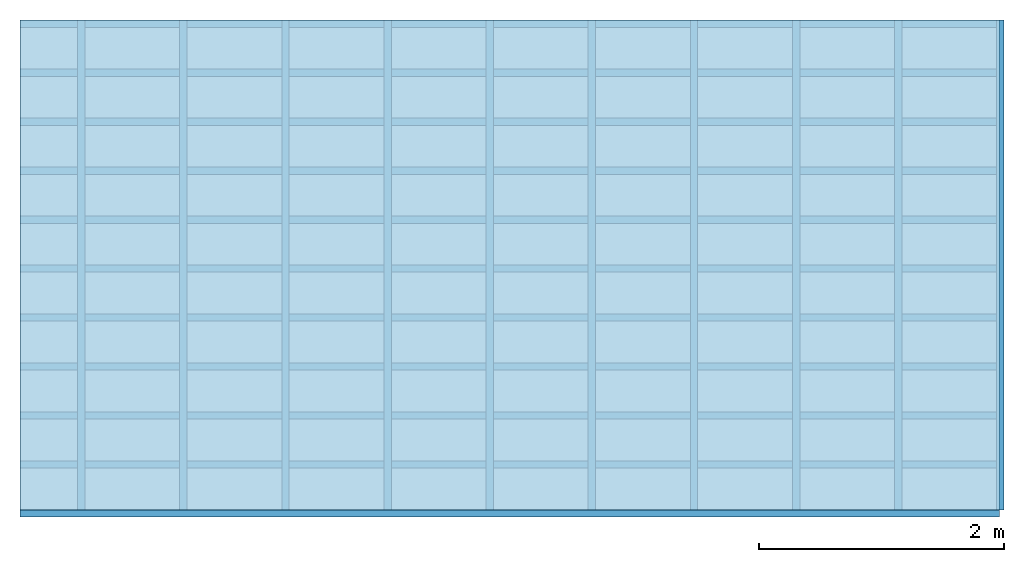
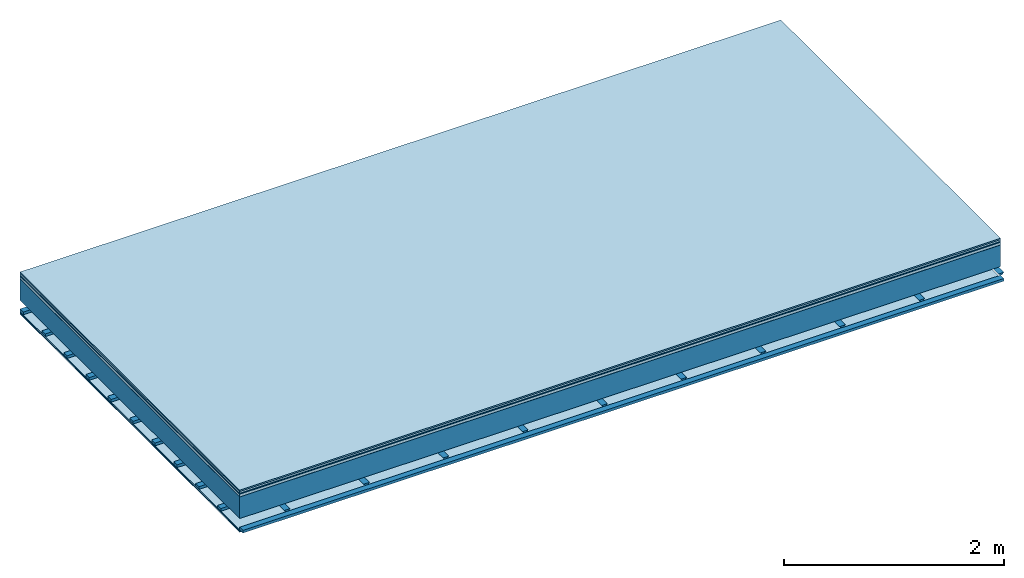
# One storey: 8 plates, 3 members, 1 element without a shape of its own.
"""IFC4 building model written with IfcOpenShell, lengths in metres."""

from ifc_helpers import new_model, si_unit, derived_unit, direction, frame, frame_2d, origin, origin_with_axes, place, context, project, spatial, polyline, rectangle, outline, extrude, material, layer, layer_set, type_object, element, aggregate, save


model = new_model("IFC4")

# Units and contexts
plan_context = context("Plan", 3, precision=1e-05, world=origin(), true_north=direction((0.0, 1.0)))
model_context = context("Model", 3, precision=1e-05, world=origin(), true_north=direction((0.0, 1.0)))
ifc_project = project(units=[si_unit("LENGTHUNIT", "METRE"), derived_unit("SOUNDPRESSUREUNIT", [(si_unit("PRESSUREUNIT", "PASCAL", prefix="MICRO"), 0)]), si_unit("ENERGYUNIT", "JOULE", prefix="MEGA"), si_unit("MASSUNIT", "GRAM", prefix="KILO"), derived_unit("THERMALTRANSMITTANCEUNIT", [(si_unit("POWERUNIT", "WATT"), 1), (si_unit("AREAUNIT", "SQUARE_METRE"), -1), (si_unit("THERMODYNAMICTEMPERATUREUNIT", "KELVIN"), -1)]), derived_unit("AREADENSITYUNIT", [(si_unit("MASSUNIT", "GRAM", prefix="KILO"), 1), (si_unit("AREAUNIT", "SQUARE_METRE"), -1)]), derived_unit("USERDEFINED", [(si_unit("ENERGYUNIT", "JOULE", prefix="MEGA"), 1), (si_unit("AREAUNIT", "SQUARE_METRE"), -1)])], contexts=[plan_context, model_context])

# Site, building, storey
site = spatial("IfcSite", under=ifc_project)
building_placement = place(None, origin())
building = spatial("IfcBuilding", under=site, at=building_placement)
storey_placement = place(building_placement, origin())
storey = spatial("IfcBuildingStorey", under=building, at=storey_placement)

# Slab, members, plates
ifc_material_1 = material(Category="11.013")
ifc_layer_1 = layer(ifc_material_1, 0.015, Name="Flooring")
ifc_material_2 = material(Category="03.007")
ifc_layer_2 = layer(ifc_material_2, 0.02, Name="On-material")
ifc_material_3 = material(Name="Wood fiber generic product", Category="10.009")
ifc_layer_3 = layer(ifc_material_3, 0.01, Name="Impact sound insulation")
ifc_material_4 = material(Name="with broken")
ifc_layer_4 = layer(ifc_material_4, 0.03, Name="on Supporting structure")
ifc_material_5 = material(Name="protection", Category="09.007")
ifc_layer_5 = layer(ifc_material_5, 0.0005, Name="Sub-floor")
ifc_material_6 = material(Name="no composite action")
ifc_layer_6 = layer(ifc_material_6, 0.0, Name="Bond")
ifc_layer_7 = layer(None, 0.24, Name="Supporting structure")
ifc_layer_8 = layer(ifc_material_6, 0.0, Name="Bond")
ifc_layer_9 = layer(None, 0.095, Name="Coupling")
ifc_layer_10 = layer(None, 0.03, Name="Battens / profiles")
ifc_material_7 = material(Name="Plasterboard type A", Category="03.008")
ifc_layer_11 = layer(ifc_material_7, 0.0125, Name="Ceiling covering 1st layer")
ifc_layer_12 = layer(ifc_material_7, 0.0125, Name="Ceiling covering layer 2")
ifc_material_8 = material(Category="04.001")
ifc_layer_13 = layer(ifc_material_8, 0.003, Name="Surface / treatment")
ifc_layer_set = layer_set([ifc_layer_1, ifc_layer_2, ifc_layer_3, ifc_layer_4, ifc_layer_5, ifc_layer_6, ifc_layer_7, ifc_layer_8, ifc_layer_9, ifc_layer_10, ifc_layer_11, ifc_layer_12, ifc_layer_13])
slab_type = type_object("IfcSlabType", Name="A2120", PredefinedType="NOTDEFINED", material=ifc_layer_set)
slab_placement = place(None, frame((0.0, 0.0, 0.0), z_axis=(0.0, 0.0, -1.0), x_axis=(1.0, 0.0, 0.0)))
slab = element("IfcSlab", 1, at=slab_placement, inside=storey, type_object=slab_type, material=ifc_layer_set, Name="Slab #1")
ifc_material_9 = material(Name="Solid timber panel")
member_1_placement = place(slab_placement, origin())
member_1 = element("IfcMember", 2, at=member_1_placement, material=ifc_material_9, Name="Supporting structure", context=plan_context, shape_type="SweptSolid", body=[
    extrude(rectangle(XDim=1.0, YDim=0.24, at=frame_2d((0.5, 0.12), x_axis=(1.0, 0.0))), frame((0.0, 4.0, 0.0755), z_axis=(0.0, -1.0, 0.0), x_axis=(1.0, 0.0, 0.0)), (0.0, 0.0, 1.0), 4.0),
    extrude(rectangle(XDim=1.0, YDim=0.24, at=frame_2d((0.5, 0.12), x_axis=(1.0, 0.0))), frame((1.0, 4.0, 0.0755), z_axis=(0.0, -1.0, 0.0), x_axis=(1.0, 0.0, 0.0)), (0.0, 0.0, 1.0), 4.0),
    extrude(rectangle(XDim=1.0, YDim=0.24, at=frame_2d((0.5, 0.12), x_axis=(1.0, 0.0))), frame((2.0, 4.0, 0.0755), z_axis=(0.0, -1.0, 0.0), x_axis=(1.0, 0.0, 0.0)), (0.0, 0.0, 1.0), 4.0),
    extrude(rectangle(XDim=1.0, YDim=0.24, at=frame_2d((0.5, 0.12), x_axis=(1.0, 0.0))), frame((3.0, 4.0, 0.0755), z_axis=(0.0, -1.0, 0.0), x_axis=(1.0, 0.0, 0.0)), (0.0, 0.0, 1.0), 4.0),
    extrude(rectangle(XDim=1.0, YDim=0.24, at=frame_2d((0.5, 0.12), x_axis=(1.0, 0.0))), frame((4.0, 4.0, 0.0755), z_axis=(0.0, -1.0, 0.0), x_axis=(1.0, 0.0, 0.0)), (0.0, 0.0, 1.0), 4.0),
    extrude(rectangle(XDim=1.0, YDim=0.24, at=frame_2d((0.5, 0.12), x_axis=(1.0, 0.0))), frame((5.0, 4.0, 0.0755), z_axis=(0.0, -1.0, 0.0), x_axis=(1.0, 0.0, 0.0)), (0.0, 0.0, 1.0), 4.0),
    extrude(rectangle(XDim=1.0, YDim=0.24, at=frame_2d((0.5, 0.12), x_axis=(1.0, 0.0))), frame((6.0, 4.0, 0.0755), z_axis=(0.0, -1.0, 0.0), x_axis=(1.0, 0.0, 0.0)), (0.0, 0.0, 1.0), 4.0),
    extrude(rectangle(XDim=1.0, YDim=0.24, at=frame_2d((0.5, 0.12), x_axis=(1.0, 0.0))), frame((7.0, 4.0, 0.0755), z_axis=(0.0, -1.0, 0.0), x_axis=(1.0, 0.0, 0.0)), (0.0, 0.0, 1.0), 4.0),
])
ifc_material_10 = material()
member_2_placement = place(slab_placement, origin())
member_2 = element("IfcMember", 3, at=member_2_placement, material=ifc_material_10, Name="Coupling", context=plan_context, shape_type="SweptSolid", body=[
    extrude(outline(polyline([(0.0, 0.0), (0.06, 0.0), (0.04, 0.02), (0.02, 0.02), (0.0, 0.0)])), frame((0.47, 4.0, 0.3905), z_axis=(0.0, -1.0, 0.0), x_axis=(1.0, 0.0, 0.0)), (0.0, 0.0, 1.0), 4.0),
    extrude(outline(polyline([(0.0, 0.0), (0.06, 0.0), (0.04, 0.02), (0.02, 0.02), (0.0, 0.0)])), frame((1.304, 4.0, 0.3905), z_axis=(0.0, -1.0, 0.0), x_axis=(1.0, 0.0, 0.0)), (0.0, 0.0, 1.0), 4.0),
    extrude(outline(polyline([(0.0, 0.0), (0.06, 0.0), (0.04, 0.02), (0.02, 0.02), (0.0, 0.0)])), frame((2.138, 4.0, 0.3905), z_axis=(0.0, -1.0, 0.0), x_axis=(1.0, 0.0, 0.0)), (0.0, 0.0, 1.0), 4.0),
    extrude(outline(polyline([(0.0, 0.0), (0.06, 0.0), (0.04, 0.02), (0.02, 0.02), (0.0, 0.0)])), frame((2.972, 4.0, 0.3905), z_axis=(0.0, -1.0, 0.0), x_axis=(1.0, 0.0, 0.0)), (0.0, 0.0, 1.0), 4.0),
    extrude(outline(polyline([(0.0, 0.0), (0.06, 0.0), (0.04, 0.02), (0.02, 0.02), (0.0, 0.0)])), frame((3.806, 4.0, 0.3905), z_axis=(0.0, -1.0, 0.0), x_axis=(1.0, 0.0, 0.0)), (0.0, 0.0, 1.0), 4.0),
    extrude(outline(polyline([(0.0, 0.0), (0.06, 0.0), (0.04, 0.02), (0.02, 0.02), (0.0, 0.0)])), frame((4.64, 4.0, 0.3905), z_axis=(0.0, -1.0, 0.0), x_axis=(1.0, 0.0, 0.0)), (0.0, 0.0, 1.0), 4.0),
    extrude(outline(polyline([(0.0, 0.0), (0.06, 0.0), (0.04, 0.02), (0.02, 0.02), (0.0, 0.0)])), frame((5.474, 4.0, 0.3905), z_axis=(0.0, -1.0, 0.0), x_axis=(1.0, 0.0, 0.0)), (0.0, 0.0, 1.0), 4.0),
    extrude(outline(polyline([(0.0, 0.0), (0.06, 0.0), (0.04, 0.02), (0.02, 0.02), (0.0, 0.0)])), frame((6.308, 4.0, 0.3905), z_axis=(0.0, -1.0, 0.0), x_axis=(1.0, 0.0, 0.0)), (0.0, 0.0, 1.0), 4.0),
    extrude(outline(polyline([(0.0, 0.0), (0.06, 0.0), (0.04, 0.02), (0.02, 0.02), (0.0, 0.0)])), frame((7.142, 4.0, 0.3905), z_axis=(0.0, -1.0, 0.0), x_axis=(1.0, 0.0, 0.0)), (0.0, 0.0, 1.0), 4.0),
    extrude(outline(polyline([(0.0, 0.0), (0.06, 0.0), (0.04, 0.02), (0.02, 0.02), (0.0, 0.0)])), frame((7.976, 4.0, 0.3905), z_axis=(0.0, -1.0, 0.0), x_axis=(1.0, 0.0, 0.0)), (0.0, 0.0, 1.0), 4.0),
])
member_3_placement = place(slab_placement, origin())
member_3 = element("IfcMember", 4, at=member_3_placement, material=ifc_material_10, Name="Battens / profiles", context=plan_context, shape_type="SweptSolid", body=[
    extrude(rectangle(XDim=0.06, YDim=0.03, at=frame_2d((0.03, 0.015), x_axis=(1.0, 0.0))), frame((0.0, 0.0, 0.4105), z_axis=(1.0, 0.0, 0.0), x_axis=(0.0, 1.0, 0.0)), (0.0, 0.0, 1.0), 8.0),
    extrude(rectangle(XDim=0.06, YDim=0.03, at=frame_2d((0.03, 0.015), x_axis=(1.0, 0.0))), frame((0.0, 0.4, 0.4105), z_axis=(1.0, 0.0, 0.0), x_axis=(0.0, 1.0, 0.0)), (0.0, 0.0, 1.0), 8.0),
    extrude(rectangle(XDim=0.06, YDim=0.03, at=frame_2d((0.03, 0.015), x_axis=(1.0, 0.0))), frame((0.0, 0.8, 0.4105), z_axis=(1.0, 0.0, 0.0), x_axis=(0.0, 1.0, 0.0)), (0.0, 0.0, 1.0), 8.0),
    extrude(rectangle(XDim=0.06, YDim=0.03, at=frame_2d((0.03, 0.015), x_axis=(1.0, 0.0))), frame((0.0, 1.2, 0.4105), z_axis=(1.0, 0.0, 0.0), x_axis=(0.0, 1.0, 0.0)), (0.0, 0.0, 1.0), 8.0),
    extrude(rectangle(XDim=0.06, YDim=0.03, at=frame_2d((0.03, 0.015), x_axis=(1.0, 0.0))), frame((0.0, 1.6, 0.4105), z_axis=(1.0, 0.0, 0.0), x_axis=(0.0, 1.0, 0.0)), (0.0, 0.0, 1.0), 8.0),
    extrude(rectangle(XDim=0.06, YDim=0.03, at=frame_2d((0.03, 0.015), x_axis=(1.0, 0.0))), frame((0.0, 2.0, 0.4105), z_axis=(1.0, 0.0, 0.0), x_axis=(0.0, 1.0, 0.0)), (0.0, 0.0, 1.0), 8.0),
    extrude(rectangle(XDim=0.06, YDim=0.03, at=frame_2d((0.03, 0.015), x_axis=(1.0, 0.0))), frame((0.0, 2.4, 0.4105), z_axis=(1.0, 0.0, 0.0), x_axis=(0.0, 1.0, 0.0)), (0.0, 0.0, 1.0), 8.0),
    extrude(rectangle(XDim=0.06, YDim=0.03, at=frame_2d((0.03, 0.015), x_axis=(1.0, 0.0))), frame((0.0, 2.8, 0.4105), z_axis=(1.0, 0.0, 0.0), x_axis=(0.0, 1.0, 0.0)), (0.0, 0.0, 1.0), 8.0),
    extrude(rectangle(XDim=0.06, YDim=0.03, at=frame_2d((0.03, 0.015), x_axis=(1.0, 0.0))), frame((0.0, 3.2, 0.4105), z_axis=(1.0, 0.0, 0.0), x_axis=(0.0, 1.0, 0.0)), (0.0, 0.0, 1.0), 8.0),
    extrude(rectangle(XDim=0.06, YDim=0.03, at=frame_2d((0.03, 0.015), x_axis=(1.0, 0.0))), frame((0.0, 3.6, 0.4105), z_axis=(1.0, 0.0, 0.0), x_axis=(0.0, 1.0, 0.0)), (0.0, 0.0, 1.0), 8.0),
    extrude(rectangle(XDim=0.06, YDim=0.03, at=frame_2d((0.03, 0.015), x_axis=(1.0, 0.0))), frame((0.0, 4.0, 0.4105), z_axis=(1.0, 0.0, 0.0), x_axis=(0.0, 1.0, 0.0)), (0.0, 0.0, 1.0), 8.0),
])
plate_1_placement = place(slab_placement, origin())
plate_1 = element("IfcPlate", 5, at=plate_1_placement, material=ifc_material_1, Name="Flooring", context=plan_context, shape_type="SweptSolid", body=[
    extrude(rectangle(XDim=8.0, YDim=4.0, at=frame_2d((4.0, 2.0), x_axis=(1.0, 0.0))), origin_with_axes(), (0.0, 0.0, 1.0), 0.015),
])
plate_2_placement = place(slab_placement, origin())
plate_2 = element("IfcPlate", 6, at=plate_2_placement, material=ifc_material_2, Name="On-material", context=plan_context, shape_type="SweptSolid", body=[
    extrude(rectangle(XDim=8.0, YDim=4.0, at=frame_2d((4.0, 2.0), x_axis=(1.0, 0.0))), frame((0.0, 0.0, 0.015), z_axis=(0.0, 0.0, 1.0), x_axis=(1.0, 0.0, 0.0)), (0.0, 0.0, 1.0), 0.02),
])
plate_3_placement = place(slab_placement, origin())
plate_3 = element("IfcPlate", 7, at=plate_3_placement, material=ifc_material_3, Name="Impact sound insulation", context=plan_context, shape_type="SweptSolid", body=[
    extrude(rectangle(XDim=8.0, YDim=4.0, at=frame_2d((4.0, 2.0), x_axis=(1.0, 0.0))), frame((0.0, 0.0, 0.035), z_axis=(0.0, 0.0, 1.0), x_axis=(1.0, 0.0, 0.0)), (0.0, 0.0, 1.0), 0.01),
])
plate_4_placement = place(slab_placement, origin())
plate_4 = element("IfcPlate", 8, at=plate_4_placement, material=ifc_material_4, Name="on Supporting structure", context=plan_context, shape_type="SweptSolid", body=[
    extrude(rectangle(XDim=8.0, YDim=4.0, at=frame_2d((4.0, 2.0), x_axis=(1.0, 0.0))), frame((0.0, 0.0, 0.045), z_axis=(0.0, 0.0, 1.0), x_axis=(1.0, 0.0, 0.0)), (0.0, 0.0, 1.0), 0.03),
])
plate_5_placement = place(slab_placement, origin())
plate_5 = element("IfcPlate", 9, at=plate_5_placement, material=ifc_material_5, Name="Sub-floor", context=plan_context, shape_type="SweptSolid", body=[
    extrude(rectangle(XDim=8.0, YDim=4.0, at=frame_2d((4.0, 2.0), x_axis=(1.0, 0.0))), frame((0.0, 0.0, 0.075), z_axis=(0.0, 0.0, 1.0), x_axis=(1.0, 0.0, 0.0)), (0.0, 0.0, 1.0), 0.0005),
])
plate_6_placement = place(slab_placement, origin())
plate_6 = element("IfcPlate", 10, at=plate_6_placement, material=ifc_material_7, Name="Ceiling covering 1st layer", context=plan_context, shape_type="SweptSolid", body=[
    extrude(rectangle(XDim=8.0, YDim=4.0, at=frame_2d((4.0, 2.0), x_axis=(1.0, 0.0))), frame((0.0, 0.0, 0.4405), z_axis=(0.0, 0.0, 1.0), x_axis=(1.0, 0.0, 0.0)), (0.0, 0.0, 1.0), 0.0125),
])
plate_7_placement = place(slab_placement, origin())
plate_7 = element("IfcPlate", 11, at=plate_7_placement, material=ifc_material_7, Name="Ceiling covering layer 2", context=plan_context, shape_type="SweptSolid", body=[
    extrude(rectangle(XDim=8.0, YDim=4.0, at=frame_2d((4.0, 2.0), x_axis=(1.0, 0.0))), frame((0.0, 0.0, 0.453), z_axis=(0.0, 0.0, 1.0), x_axis=(1.0, 0.0, 0.0)), (0.0, 0.0, 1.0), 0.0125),
])
plate_8_placement = place(slab_placement, origin())
plate_8 = element("IfcPlate", 12, at=plate_8_placement, material=ifc_material_8, Name="Surface / treatment", context=plan_context, shape_type="SweptSolid", body=[
    extrude(rectangle(XDim=8.0, YDim=4.0, at=frame_2d((4.0, 2.0), x_axis=(1.0, 0.0))), frame((0.0, 0.0, 0.4655), z_axis=(0.0, 0.0, 1.0), x_axis=(1.0, 0.0, 0.0)), (0.0, 0.0, 1.0), 0.003),
])
aggregate(slab, [plate_1, plate_2, plate_3, plate_4, plate_5, member_1, member_2, member_3, plate_6, plate_7, plate_8])

save(model, "model.ifc")
